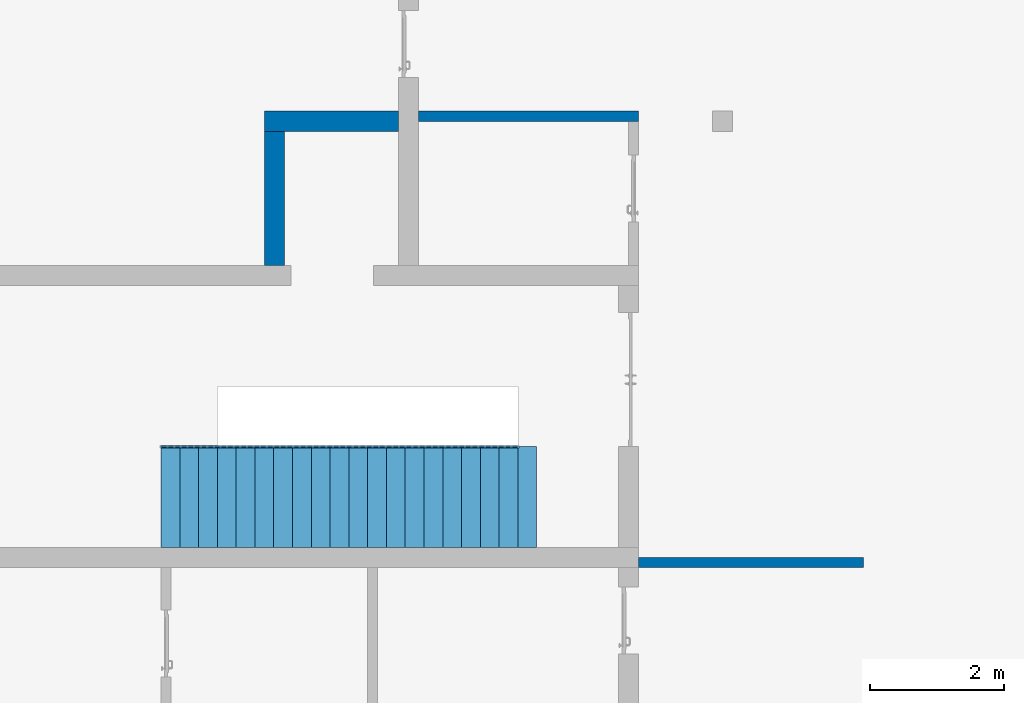
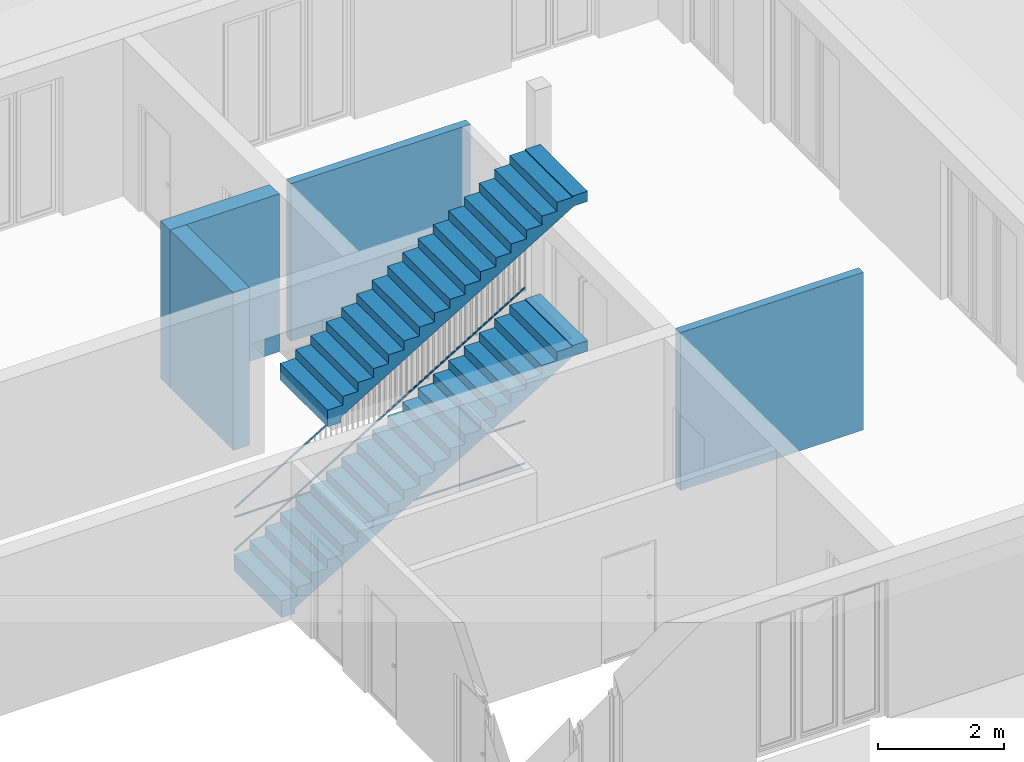
# One storey, part 19 of 23: 6 building element parts, 4 walls, 4 elements without a shape of their own.
"""IFC4 building model written with IfcOpenShell, lengths in metres."""

from ifc_helpers import new_model, entity, si_unit, converted_unit, derived_unit, direction, frame, origin_with_axes, place, context, subcontext, project, spatial, polygons, material, type_object, element, aggregate, save


model = new_model("IFC4")

# Units and contexts
model_context = context("Model", 3, precision=1e-05, world=origin_with_axes(), true_north=direction((0.0, 1.0)))
body_context = subcontext(model_context, "Body", "Model", "MODEL_VIEW")
ifc_project = project(units=[si_unit("LENGTHUNIT", "METRE"), si_unit("AREAUNIT", "SQUARE_METRE"), si_unit("VOLUMEUNIT", "CUBIC_METRE"), converted_unit("PLANEANGLEUNIT", "DEGREE", entity("IfcPlaneAngleMeasure", 0.0174532925199), si_unit("PLANEANGLEUNIT", "RADIAN"), dimensions=[0, 0, 0, 0, 0, 0, 0]), converted_unit("TIMEUNIT", "Year", entity("IfcTimeMeasure", 31556926.0), si_unit("TIMEUNIT", "SECOND"), dimensions=[0, 0, 1, 0, 0, 0, 0]), si_unit("MASSUNIT", "GRAM", prefix="KILO"), si_unit("THERMODYNAMICTEMPERATUREUNIT", "DEGREE_CELSIUS"), si_unit("LUMINOUSINTENSITYUNIT", "LUMEN"), si_unit("ENERGYUNIT", "JOULE", prefix="MEGA"), derived_unit("THERMALCONDUCTANCEUNIT", [(si_unit("POWERUNIT", "WATT"), 1), (si_unit("LENGTHUNIT", "METRE"), -1), (si_unit("THERMODYNAMICTEMPERATUREUNIT", "KELVIN"), -1)]), derived_unit("SPECIFICHEATCAPACITYUNIT", [(si_unit("ENERGYUNIT", "JOULE"), 1), (si_unit("MASSUNIT", "GRAM", prefix="KILO"), -1), (si_unit("THERMODYNAMICTEMPERATUREUNIT", "KELVIN"), -1)]), derived_unit("MASSDENSITYUNIT", [(si_unit("MASSUNIT", "GRAM", prefix="KILO"), 1), (si_unit("VOLUMEUNIT", "CUBIC_METRE"), -1)])], contexts=[model_context])

# Site, building, storey
site_placement = place(None, origin_with_axes())
site = spatial("IfcSite", under=ifc_project, at=site_placement, CompositionType="ELEMENT")
building_placement = place(site_placement, origin_with_axes())
building = spatial("IfcBuilding", under=site, at=building_placement, CompositionType="ELEMENT")
storey_placement = place(building_placement, origin_with_axes())
storey = spatial("IfcBuildingStorey", under=building, at=storey_placement, Name="0. Geschoss", CompositionType="ELEMENT", Elevation=0.0)

# Walls
ifc_material_1 = material()
wall_type_1 = type_object("IfcWallType", Name="300", PredefinedType="NOTDEFINED")
wall_1_placement = place(storey_placement, frame((-2.7421993804, 3.67118776896, 0.0), z_axis=(0.0, 0.0, 1.0), x_axis=(1.0, 0.0, 0.0)))
element("IfcWall", 1, at=wall_1_placement, inside=storey, type_object=wall_type_1, material=ifc_material_1, Name="Wand-001", PredefinedType="NOTDEFINED", context=body_context, shape_type="Tessellation", body=[
    polygons([(0.0, 0.3, 0.0), (0.0, 0.3, 3.05), (2.0, 0.3, 3.05), (2.0, 0.3, 0.0), (0.0, 0.0, 0.0), (0.0, 0.0, 3.05), (2.0, 0.0, 3.05), (2.0, 0.0, 0.0)], [[[1, 2, 3, 4]], [[5, 6, 2, 1]], [[6, 7, 3, 2]], [[4, 3, 7, 8]], [[1, 4, 8, 5]], [[8, 7, 6, 5]]], closed=True),
])
wall_2_placement = place(storey_placement, frame((-2.7421993804, 1.37118776896, 0.0), z_axis=(0.0, 0.0, 1.0), x_axis=(0.0, 1.0, 0.0)))
element("IfcWall", 2, at=wall_2_placement, inside=storey, type_object=wall_type_1, material=ifc_material_1, Name="Wand-001", PredefinedType="NOTDEFINED", context=body_context, shape_type="Tessellation", body=[
    polygons([(2.3, 0.0, 0.0), (2.3, 0.0, 3.05), (2.3, -0.3, 3.05), (2.3, -0.3, 0.0), (0.3, 0.0, 0.0), (0.3, 0.0, 3.05), (0.3, -0.3, 3.05), (0.3, -0.3, 0.0)], [[[1, 2, 3, 4]], [[5, 6, 2, 1]], [[6, 7, 3, 2]], [[4, 3, 7, 8]], [[5, 1, 4, 8]], [[8, 7, 6, 5]]], closed=True),
])
wall_type_2 = type_object("IfcWallType", Name="150", PredefinedType="NOTDEFINED")
wall_3_placement = place(storey_placement, frame((-0.742199380397, 3.97118776896, 0.0), z_axis=(0.0, 0.0, 1.0), x_axis=(1.0, 0.0, 0.0)))
element("IfcWall", 3, at=wall_3_placement, inside=storey, type_object=wall_type_2, material=ifc_material_1, Name="Wand-002", PredefinedType="NOTDEFINED", context=body_context, shape_type="Tessellation", body=[
    polygons([(0.3, 0.0, 0.0), (0.3, 0.0, 3.05), (3.58, 0.0, 3.05), (3.58, 0.0, 0.0), (0.3, -0.15, 0.0), (0.3, -0.15, 3.05), (3.58, -0.15, 3.05), (3.58, -0.15, 0.0)], [[[1, 2, 3, 4]], [[5, 6, 2, 1]], [[6, 7, 3, 2]], [[4, 3, 7, 8]], [[1, 4, 8, 5]], [[8, 7, 6, 5]]], closed=True),
])
wall_4_placement = place(storey_placement, frame((2.6878006196, -2.82881223104, 0.0), z_axis=(0.0, 0.0, 1.0), x_axis=(1.0, 0.0, 0.0)))
element("IfcWall", 4, at=wall_4_placement, inside=storey, type_object=wall_type_2, material=ifc_material_1, Name="Wand-002", PredefinedType="NOTDEFINED", context=body_context, shape_type="Tessellation", body=[
    polygons([(0.15, 0.15, 0.0), (0.15, 0.15, 3.05), (3.5, 0.15, 3.05), (3.5, 0.15, 0.0), (0.15, 0.0, 0.0), (0.15, 0.0, 3.05), (3.5, 0.0, 3.05), (3.5, 0.0, 0.0)], [[[1, 2, 3, 4]], [[5, 6, 2, 1]], [[6, 7, 3, 2]], [[4, 3, 7, 8]], [[5, 1, 4, 8]], [[8, 7, 6, 5]]], closed=True),
])

# Space
space_1_placement = place(storey_placement, frame((-11.4421993804, 1.37118776896, 0.0), z_axis=(0.0, 0.0, 1.0), x_axis=(0.0, -1.0, 0.0)))
space_1 = spatial("IfcSpace", under=storey, at=space_1_placement, CompositionType="ELEMENT", PredefinedType="INTERNAL")

# Railing, building element parts
railing_type = type_object("IfcRailingType", PredefinedType="NOTDEFINED")
railing_1_placement = place(space_1_placement, frame((1.5, 8.0, 0.0), z_axis=(0.0, 0.0, 1.0), x_axis=(0.0, 1.0, 0.0)))
railing_1 = element("IfcRailing", 5, at=railing_1_placement, inside=space_1, type_object=railing_type, PredefinedType="NOTDEFINED")
ifc_material_2 = material()
building_element_part_1_placement = place(railing_1_placement, origin_with_axes())
building_element_part_1 = element("IfcBuildingElementPart", 6, at=building_element_part_1_placement, material=ifc_material_2, PredefinedType="NOTDEFINED", context=body_context, shape_type="Tessellation", body=[
    polygons([(-0.84, -0.9125, 0.9), (-0.84, -0.9125, 0.875), (4.48, -0.9125, 0.875), (4.48, -0.9125, 0.9), (-0.84, -0.8875, 0.9), (-0.84, -0.8875, 0.875), (4.48, -0.8875, 0.875), (4.48, -0.8875, 0.9)], [[[1, 2, 3, 4]], [[1, 5, 6, 2]], [[2, 6, 7, 3]], [[4, 3, 7, 8]], [[5, 1, 4, 8]], [[6, 5, 8, 7]]], closed=True),
])
building_element_part_2_placement = place(railing_1_placement, origin_with_axes())
building_element_part_2 = element("IfcBuildingElementPart", 7, at=building_element_part_2_placement, material=ifc_material_2, PredefinedType="NOTDEFINED", context=body_context, shape_type="Tessellation", body=[
    polygons([(-0.84, -0.9125, 0.0825), (-0.84, -0.9125, 0.0575), (4.48, -0.9125, 0.0575), (4.48, -0.9125, 0.0825), (-0.84, -0.8875, 0.0825), (-0.84, -0.8875, 0.0575), (4.48, -0.8875, 0.0575), (4.48, -0.8875, 0.0825)], [[[1, 2, 3, 4]], [[1, 5, 6, 2]], [[2, 6, 7, 3]], [[4, 3, 7, 8]], [[5, 1, 4, 8]], [[6, 5, 8, 7]]], closed=True),
])
aggregate(railing_1, [building_element_part_1, building_element_part_2])

# Stair, building element part
stair_type = type_object("IfcStairType", PredefinedType="NOTDEFINED")
stair_1_placement = place(space_1_placement, frame((2.4, 7.16, 0.0), z_axis=(0.0, 0.0, 1.0), x_axis=(0.0, 1.0, 0.0)))
stair_1 = element("IfcStair", 8, at=stair_1_placement, inside=space_1, type_object=stair_type, Name="Treppe - 001", PredefinedType="NOTDEFINED")
building_element_part_3_placement = place(stair_1_placement, origin_with_axes())
building_element_part_3 = element("IfcBuildingElementPart", 9, at=building_element_part_3_placement, material=ifc_material_1, PredefinedType="NOTDEFINED", context=body_context, shape_type="Tessellation", body=[
    polygons([(5.6, 0.0, 3.25), (5.6, -1.5, 3.25), (5.6, -1.5, 3.20112016499), (5.6, 0.0, 3.20112016499), (5.32, 0.0, 3.25), (5.32, -1.5, 3.25), (5.35109619885, -1.5, 3.05), (5.6, -1.5, 3.05), (5.32, -1.5, 3.23), (5.04, -1.5, 3.23), (5.04, -1.5, 3.06), (4.76, -1.5, 3.06), (4.76, -1.5, 2.89), (4.48, -1.5, 2.89), (4.48, -1.5, 2.72), (4.2, -1.5, 2.72), (4.2, -1.5, 2.55), (3.92, -1.5, 2.55), (3.92, -1.5, 2.38), (3.64, -1.5, 2.38), (3.64, -1.5, 2.21), (3.36, -1.5, 2.21), (3.36, -1.5, 2.04), (3.08, -1.5, 2.04), (3.08, -1.5, 1.87), (2.8, -1.5, 1.87), (2.8, -1.5, 1.7), (2.52, -1.5, 1.7), (2.52, -1.5, 1.53), (2.24, -1.5, 1.53), (2.24, -1.5, 1.36), (1.96, -1.5, 1.36), (1.96, -1.5, 1.19), (1.68, -1.5, 1.19), (1.68, -1.5, 1.02), (1.4, -1.5, 1.02), (1.4, -1.5, 0.85), (1.12, -1.5, 0.85), (1.12, -1.5, 0.68), (0.84, -1.5, 0.68), (0.84, -1.5, 0.51), (0.56, -1.5, 0.51), (0.56, -1.5, 0.34), (0.28, -1.5, 0.34), (0.28, -1.5, 0.17), (0.0, -1.5, 0.17), (0.0, -1.5, -0.15), (0.25, -1.5, -0.15), (0.25, -1.5, -0.0470941207291), (0.28, -1.5, -0.0288798350148), (0.373333333333, -1.5, 0.0277868316519), (0.466666666667, -1.5, 0.0844534983185), (0.56, -1.5, 0.141120164985), (0.653333333333, -1.5, 0.197786831652), (0.746666666667, -1.5, 0.254453498319), (0.84, -1.5, 0.311120164985), (0.933333333333, -1.5, 0.367786831652), (1.02666666667, -1.5, 0.424453498319), (1.12, -1.5, 0.481120164985), (1.21333333333, -1.5, 0.537786831652), (1.30666666667, -1.5, 0.594453498319), (1.4, -1.5, 0.651120164985), (1.49333333333, -1.5, 0.707786831652), (1.58666666667, -1.5, 0.764453498319), (1.68, -1.5, 0.821120164985), (1.77333333333, -1.5, 0.877786831652), (1.86666666667, -1.5, 0.934453498319), (1.96, -1.5, 0.991120164985), (2.05333333333, -1.5, 1.04778683165), (2.14666666667, -1.5, 1.10445349832), (2.24, -1.5, 1.16112016499), (2.33333333333, -1.5, 1.21778683165), (2.42666666667, -1.5, 1.27445349832), (2.52, -1.5, 1.33112016499), (2.61333333333, -1.5, 1.38778683165), (2.70666666667, -1.5, 1.44445349832), (2.8, -1.5, 1.50112016499), (2.89333333333, -1.5, 1.55778683165), (2.98666666667, -1.5, 1.61445349832), (3.08, -1.5, 1.67112016499), (3.17333333333, -1.5, 1.72778683165), (3.26666666667, -1.5, 1.78445349832), (3.36, -1.5, 1.84112016499), (3.45333333333, -1.5, 1.89778683165), (3.54666666667, -1.5, 1.95445349832), (3.64, -1.5, 2.01112016499), (3.73333333333, -1.5, 2.06778683165), (3.82666666667, -1.5, 2.12445349832), (3.92, -1.5, 2.18112016499), (4.01333333333, -1.5, 2.23778683165), (4.10666666667, -1.5, 2.29445349832), (4.2, -1.5, 2.35112016499), (4.29333333333, -1.5, 2.40778683165), (4.38666666667, -1.5, 2.46445349832), (4.48, -1.5, 2.52112016499), (4.57333333333, -1.5, 2.57778683165), (4.66666666667, -1.5, 2.63445349832), (4.76, -1.5, 2.69112016499), (4.85333333333, -1.5, 2.74778683165), (4.94666666667, -1.5, 2.80445349832), (5.04, -1.5, 2.86112016499), (5.13333333333, -1.5, 2.91778683165), (5.22666666667, -1.5, 2.97445349832), (5.32, -1.5, 3.03112016499), (5.6, 0.0, 3.05), (5.35109619885, 0.0, 3.05), (5.32, 0.0, 3.03112016499), (5.22666666667, 0.0, 2.97445349832), (5.13333333333, 0.0, 2.91778683165), (5.04, 0.0, 2.86112016499), (4.94666666667, 0.0, 2.80445349832), (4.85333333333, 0.0, 2.74778683165), (4.76, 0.0, 2.69112016499), (4.66666666667, 0.0, 2.63445349832), (4.57333333333, 0.0, 2.57778683165), (4.48, 0.0, 2.52112016499), (4.38666666667, 0.0, 2.46445349832), (4.29333333333, 0.0, 2.40778683165), (4.2, 0.0, 2.35112016499), (4.10666666667, 0.0, 2.29445349832), (4.01333333333, 0.0, 2.23778683165), (3.92, 0.0, 2.18112016499), (3.82666666667, 0.0, 2.12445349832), (3.73333333333, 0.0, 2.06778683165), (3.64, 0.0, 2.01112016499), (3.54666666667, 0.0, 1.95445349832), (3.45333333333, 0.0, 1.89778683165), (3.36, 0.0, 1.84112016499), (3.26666666667, 0.0, 1.78445349832), (3.17333333333, 0.0, 1.72778683165), (3.08, 0.0, 1.67112016499), (2.98666666667, 0.0, 1.61445349832), (2.89333333333, 0.0, 1.55778683165), (2.8, 0.0, 1.50112016499), (2.70666666667, 0.0, 1.44445349832), (2.61333333333, 0.0, 1.38778683165), (2.52, 0.0, 1.33112016499), (2.42666666667, 0.0, 1.27445349832), (2.33333333333, 0.0, 1.21778683165), (2.24, 0.0, 1.16112016499), (2.14666666667, 0.0, 1.10445349832), (2.05333333333, 0.0, 1.04778683165), (1.96, 0.0, 0.991120164985), (1.86666666667, 0.0, 0.934453498319), (1.77333333333, 0.0, 0.877786831652), (1.68, 0.0, 0.821120164985), (1.58666666667, 0.0, 0.764453498319), (1.49333333333, 0.0, 0.707786831652), (1.4, 0.0, 0.651120164985), (1.30666666667, 0.0, 0.594453498319), (1.21333333333, 0.0, 0.537786831652), (1.12, 0.0, 0.481120164985), (1.02666666667, 0.0, 0.424453498319), (0.933333333333, 0.0, 0.367786831652), (0.84, 0.0, 0.311120164985), (0.746666666667, 0.0, 0.254453498319), (0.653333333333, 0.0, 0.197786831652), (0.56, 0.0, 0.141120164985), (0.466666666667, 0.0, 0.0844534983185), (0.373333333333, 0.0, 0.0277868316519), (0.28, 0.0, -0.0288798350148), (0.25, 0.0, -0.0470941207291), (0.25, 0.0, -0.15), (0.0, 0.0, -0.15), (0.0, 0.0, 0.17), (0.28, 0.0, 0.17), (0.28, 0.0, 0.34), (0.56, 0.0, 0.34), (0.56, 0.0, 0.51), (0.84, 0.0, 0.51), (0.84, 0.0, 0.68), (1.12, 0.0, 0.68), (1.12, 0.0, 0.85), (1.4, 0.0, 0.85), (1.4, 0.0, 1.02), (1.68, 0.0, 1.02), (1.68, 0.0, 1.19), (1.96, 0.0, 1.19), (1.96, 0.0, 1.36), (2.24, 0.0, 1.36), (2.24, 0.0, 1.53), (2.52, 0.0, 1.53), (2.52, 0.0, 1.7), (2.8, 0.0, 1.7), (2.8, 0.0, 1.87), (3.08, 0.0, 1.87), (3.08, 0.0, 2.04), (3.36, 0.0, 2.04), (3.36, 0.0, 2.21), (3.64, 0.0, 2.21), (3.64, 0.0, 2.38), (3.92, 0.0, 2.38), (3.92, 0.0, 2.55), (4.2, 0.0, 2.55), (4.2, 0.0, 2.72), (4.48, 0.0, 2.72), (4.48, 0.0, 2.89), (4.76, 0.0, 2.89), (4.76, 0.0, 3.06), (5.04, 0.0, 3.06), (5.04, 0.0, 3.23), (5.32, 0.0, 3.23)], [[[1, 2, 3, 4]], [[2, 1, 5, 6]], [[7, 8, 3, 2, 6, 9, 10, 11, 12, 13, 14, 15, 16, 17, 18, 19, 20, 21, 22, 23, 24, 25, 26, 27, 28, 29, 30, 31, 32, 33, 34, 35, 36, 37, 38, 39, 40, 41, 42, 43, 44, 45, 46, 47, 48, 49, 50, 51, 52, 53, 54, 55, 56, 57, 58, 59, 60, 61, 62, 63, 64, 65, 66, 67, 68, 69, 70, 71, 72, 73, 74, 75, 76, 77, 78, 79, 80, 81, 82, 83, 84, 85, 86, 87, 88, 89, 90, 91, 92, 93, 94, 95, 96, 97, 98, 99, 100, 101, 102, 103, 104]], [[8, 105, 4, 3]], [[5, 1, 4, 105, 106, 107, 108, 109, 110, 111, 112, 113, 114, 115, 116, 117, 118, 119, 120, 121, 122, 123, 124, 125, 126, 127, 128, 129, 130, 131, 132, 133, 134, 135, 136, 137, 138, 139, 140, 141, 142, 143, 144, 145, 146, 147, 148, 149, 150, 151, 152, 153, 154, 155, 156, 157, 158, 159, 160, 161, 162, 163, 164, 165, 166, 167, 168, 169, 170, 171, 172, 173, 174, 175, 176, 177, 178, 179, 180, 181, 182, 183, 184, 185, 186, 187, 188, 189, 190, 191, 192, 193, 194, 195, 196, 197, 198, 199, 200, 201, 202]], [[5, 202, 9, 6]], [[105, 8, 7, 106]], [[10, 9, 202, 201]], [[201, 200, 11, 10]], [[12, 11, 200, 199]], [[199, 198, 13, 12]], [[14, 13, 198, 197]], [[197, 196, 15, 14]], [[16, 15, 196, 195]], [[195, 194, 17, 16]], [[18, 17, 194, 193]], [[193, 192, 19, 18]], [[20, 19, 192, 191]], [[191, 190, 21, 20]], [[22, 21, 190, 189]], [[189, 188, 23, 22]], [[24, 23, 188, 187]], [[187, 186, 25, 24]], [[26, 25, 186, 185]], [[185, 184, 27, 26]], [[28, 27, 184, 183]], [[183, 182, 29, 28]], [[30, 29, 182, 181]], [[181, 180, 31, 30]], [[32, 31, 180, 179]], [[179, 178, 33, 32]], [[34, 33, 178, 177]], [[177, 176, 35, 34]], [[36, 35, 176, 175]], [[175, 174, 37, 36]], [[38, 37, 174, 173]], [[173, 172, 39, 38]], [[40, 39, 172, 171]], [[171, 170, 41, 40]], [[42, 41, 170, 169]], [[169, 168, 43, 42]], [[44, 43, 168, 167]], [[167, 166, 45, 44]], [[46, 45, 166, 165]], [[164, 47, 46, 165]], [[47, 164, 163, 48]], [[49, 48, 163, 162]], [[162, 161, 50, 49]], [[161, 160, 51, 50]], [[160, 159, 52, 51]], [[159, 158, 53, 52]], [[158, 157, 54, 53]], [[157, 156, 55, 54]], [[156, 155, 56, 55]], [[155, 154, 57, 56]], [[154, 153, 58, 57]], [[153, 152, 59, 58]], [[152, 151, 60, 59]], [[151, 150, 61, 60]], [[150, 149, 62, 61]], [[149, 148, 63, 62]], [[148, 147, 64, 63]], [[147, 146, 65, 64]], [[146, 145, 66, 65]], [[145, 144, 67, 66]], [[144, 143, 68, 67]], [[143, 142, 69, 68]], [[142, 141, 70, 69]], [[141, 140, 71, 70]], [[140, 139, 72, 71]], [[139, 138, 73, 72]], [[138, 137, 74, 73]], [[137, 136, 75, 74]], [[136, 135, 76, 75]], [[135, 134, 77, 76]], [[134, 133, 78, 77]], [[133, 132, 79, 78]], [[132, 131, 80, 79]], [[131, 130, 81, 80]], [[130, 129, 82, 81]], [[129, 128, 83, 82]], [[128, 127, 84, 83]], [[127, 126, 85, 84]], [[126, 125, 86, 85]], [[125, 124, 87, 86]], [[124, 123, 88, 87]], [[123, 122, 89, 88]], [[122, 121, 90, 89]], [[121, 120, 91, 90]], [[120, 119, 92, 91]], [[119, 118, 93, 92]], [[118, 117, 94, 93]], [[117, 116, 95, 94]], [[116, 115, 96, 95]], [[115, 114, 97, 96]], [[114, 113, 98, 97]], [[113, 112, 99, 98]], [[112, 111, 100, 99]], [[111, 110, 101, 100]], [[110, 109, 102, 101]], [[109, 108, 103, 102]], [[108, 107, 104, 103]], [[104, 107, 106, 7]]], closed=True),
])
aggregate(stair_1, [building_element_part_3])

# Railing, building element parts
railing_2_placement = place(space_1_placement, frame((2.4, 7.16, 0.17), z_axis=(0.0, 0.0, 1.0), x_axis=(0.0, 1.0, 0.0)))
railing_2 = element("IfcRailing", 10, at=railing_2_placement, inside=space_1, type_object=railing_type, PredefinedType="NOTDEFINED")
building_element_part_4_placement = place(railing_2_placement, origin_with_axes())
building_element_part_4 = element("IfcBuildingElementPart", 11, at=building_element_part_4_placement, material=ifc_material_2, PredefinedType="NOTDEFINED", context=body_context, shape_type="Tessellation", body=[
    polygons([(0.0, -0.0125, 0.9), (0.012974453356, -0.0125, 0.878630312119), (5.33297445336, -0.0125, 4.10863031212), (5.32, -0.0125, 4.13), (0.0, 0.0125, 0.9), (0.012974453356, 0.0125, 0.878630312119), (5.33297445336, 0.0125, 4.10863031212), (5.32, 0.0125, 4.13)], [[[1, 2, 3, 4]], [[1, 5, 6, 2]], [[2, 6, 7, 3]], [[4, 3, 7, 8]], [[5, 1, 4, 8]], [[6, 5, 8, 7]]], closed=True),
])
building_element_part_5_placement = place(railing_2_placement, origin_with_axes())
building_element_part_5 = element("IfcBuildingElementPart", 12, at=building_element_part_5_placement, material=ifc_material_2, PredefinedType="NOTDEFINED", context=body_context, shape_type="Tessellation", body=[
    polygons([(-0.00648722667802, -0.0125, 0.0806848439403), (0.00648722667802, -0.0125, 0.0593151560597), (5.32648722668, -0.0125, 3.28931515606), (5.31351277332, -0.0125, 3.31068484394), (-0.00648722667802, 0.0125, 0.0806848439403), (0.00648722667802, 0.0125, 0.0593151560597), (5.32648722668, 0.0125, 3.28931515606), (5.31351277332, 0.0125, 3.31068484394)], [[[1, 2, 3, 4]], [[1, 5, 6, 2]], [[2, 6, 7, 3]], [[4, 3, 7, 8]], [[5, 1, 4, 8]], [[6, 5, 8, 7]]], closed=True),
])
aggregate(railing_2, [building_element_part_4, building_element_part_5])

# Space
space_2_placement = place(storey_placement, frame((-3.4421993804, -2.52881223104, 0.0), z_axis=(0.0, 0.0, 1.0), x_axis=(1.0, 0.0, 0.0)))
space_2 = spatial("IfcSpace", under=storey, at=space_2_placement, CompositionType="ELEMENT", PredefinedType="INTERNAL")

# Stair, building element part
stair_2_placement = place(space_2_placement, frame((0.0, 1.5, 3.4), z_axis=(0.0, 0.0, 1.0), x_axis=(1.0, 0.0, 0.0)))
stair_2 = element("IfcStair", 13, at=stair_2_placement, inside=space_2, type_object=stair_type, Name="Treppe - 001", PredefinedType="NOTDEFINED")
building_element_part_6_placement = place(stair_2_placement, origin_with_axes())
building_element_part_6 = element("IfcBuildingElementPart", 14, at=building_element_part_6_placement, material=ifc_material_1, PredefinedType="NOTDEFINED", context=body_context, shape_type="Tessellation", body=[
    polygons([(4.76, 0.0, 2.74), (4.76, -1.5, 2.74), (4.76, -1.5, 2.69112016499), (4.76, 0.0, 2.69112016499), (4.48, 0.0, 2.74), (4.48, -1.5, 2.74), (4.51109619885, -1.5, 2.54), (4.76, -1.5, 2.54), (4.48, -1.5, 2.72), (4.2, -1.5, 2.72), (4.2, -1.5, 2.55), (3.92, -1.5, 2.55), (3.92, -1.5, 2.38), (3.64, -1.5, 2.38), (3.64, -1.5, 2.21), (3.36, -1.5, 2.21), (3.36, -1.5, 2.04), (3.08, -1.5, 2.04), (3.08, -1.5, 1.87), (2.8, -1.5, 1.87), (2.8, -1.5, 1.7), (2.52, -1.5, 1.7), (2.52, -1.5, 1.53), (2.24, -1.5, 1.53), (2.24, -1.5, 1.36), (1.96, -1.5, 1.36), (1.96, -1.5, 1.19), (1.68, -1.5, 1.19), (1.68, -1.5, 1.02), (1.4, -1.5, 1.02), (1.4, -1.5, 0.85), (1.12, -1.5, 0.85), (1.12, -1.5, 0.68), (0.84, -1.5, 0.68), (0.84, -1.5, 0.51), (0.56, -1.5, 0.51), (0.56, -1.5, 0.34), (0.28, -1.5, 0.34), (0.28, -1.5, 0.17), (0.0, -1.5, 0.17), (0.0, -1.5, -0.15), (0.25, -1.5, -0.15), (0.25, -1.5, -0.0470941207291), (0.28, -1.5, -0.0288798350148), (0.373333333333, -1.5, 0.0277868316519), (0.466666666667, -1.5, 0.0844534983185), (0.56, -1.5, 0.141120164985), (0.653333333333, -1.5, 0.197786831652), (0.746666666667, -1.5, 0.254453498319), (0.84, -1.5, 0.311120164985), (0.933333333333, -1.5, 0.367786831652), (1.02666666667, -1.5, 0.424453498319), (1.12, -1.5, 0.481120164985), (1.21333333333, -1.5, 0.537786831652), (1.30666666667, -1.5, 0.594453498319), (1.4, -1.5, 0.651120164985), (1.49333333333, -1.5, 0.707786831652), (1.58666666667, -1.5, 0.764453498319), (1.68, -1.5, 0.821120164985), (1.77333333333, -1.5, 0.877786831652), (1.86666666667, -1.5, 0.934453498319), (1.96, -1.5, 0.991120164985), (2.05333333333, -1.5, 1.04778683165), (2.14666666667, -1.5, 1.10445349832), (2.24, -1.5, 1.16112016499), (2.33333333333, -1.5, 1.21778683165), (2.42666666667, -1.5, 1.27445349832), (2.52, -1.5, 1.33112016499), (2.61333333333, -1.5, 1.38778683165), (2.70666666667, -1.5, 1.44445349832), (2.8, -1.5, 1.50112016499), (2.89333333333, -1.5, 1.55778683165), (2.98666666667, -1.5, 1.61445349832), (3.08, -1.5, 1.67112016499), (3.17333333333, -1.5, 1.72778683165), (3.26666666667, -1.5, 1.78445349832), (3.36, -1.5, 1.84112016499), (3.45333333333, -1.5, 1.89778683165), (3.54666666667, -1.5, 1.95445349832), (3.64, -1.5, 2.01112016499), (3.73333333333, -1.5, 2.06778683165), (3.82666666667, -1.5, 2.12445349832), (3.92, -1.5, 2.18112016499), (4.01333333333, -1.5, 2.23778683165), (4.10666666667, -1.5, 2.29445349832), (4.2, -1.5, 2.35112016499), (4.29333333333, -1.5, 2.40778683165), (4.38666666667, -1.5, 2.46445349832), (4.48, -1.5, 2.52112016499), (4.76, 0.0, 2.54), (4.51109619885, 0.0, 2.54), (4.48, 0.0, 2.52112016499), (4.38666666667, 0.0, 2.46445349832), (4.29333333333, 0.0, 2.40778683165), (4.2, 0.0, 2.35112016499), (4.10666666667, 0.0, 2.29445349832), (4.01333333333, 0.0, 2.23778683165), (3.92, 0.0, 2.18112016499), (3.82666666667, 0.0, 2.12445349832), (3.73333333333, 0.0, 2.06778683165), (3.64, 0.0, 2.01112016499), (3.54666666667, 0.0, 1.95445349832), (3.45333333333, 0.0, 1.89778683165), (3.36, 0.0, 1.84112016499), (3.26666666667, 0.0, 1.78445349832), (3.17333333333, 0.0, 1.72778683165), (3.08, 0.0, 1.67112016499), (2.98666666667, 0.0, 1.61445349832), (2.89333333333, 0.0, 1.55778683165), (2.8, 0.0, 1.50112016499), (2.70666666667, 0.0, 1.44445349832), (2.61333333333, 0.0, 1.38778683165), (2.52, 0.0, 1.33112016499), (2.42666666667, 0.0, 1.27445349832), (2.33333333333, 0.0, 1.21778683165), (2.24, 0.0, 1.16112016499), (2.14666666667, 0.0, 1.10445349832), (2.05333333333, 0.0, 1.04778683165), (1.96, 0.0, 0.991120164985), (1.86666666667, 0.0, 0.934453498319), (1.77333333333, 0.0, 0.877786831652), (1.68, 0.0, 0.821120164985), (1.58666666667, 0.0, 0.764453498319), (1.49333333333, 0.0, 0.707786831652), (1.4, 0.0, 0.651120164985), (1.30666666667, 0.0, 0.594453498319), (1.21333333333, 0.0, 0.537786831652), (1.12, 0.0, 0.481120164985), (1.02666666667, 0.0, 0.424453498319), (0.933333333333, 0.0, 0.367786831652), (0.84, 0.0, 0.311120164985), (0.746666666667, 0.0, 0.254453498319), (0.653333333333, 0.0, 0.197786831652), (0.56, 0.0, 0.141120164985), (0.466666666667, 0.0, 0.0844534983185), (0.373333333333, 0.0, 0.0277868316519), (0.28, 0.0, -0.0288798350148), (0.25, 0.0, -0.0470941207291), (0.25, 0.0, -0.15), (0.0, 0.0, -0.15), (0.0, 0.0, 0.17), (0.28, 0.0, 0.17), (0.28, 0.0, 0.34), (0.56, 0.0, 0.34), (0.56, 0.0, 0.51), (0.84, 0.0, 0.51), (0.84, 0.0, 0.68), (1.12, 0.0, 0.68), (1.12, 0.0, 0.85), (1.4, 0.0, 0.85), (1.4, 0.0, 1.02), (1.68, 0.0, 1.02), (1.68, 0.0, 1.19), (1.96, 0.0, 1.19), (1.96, 0.0, 1.36), (2.24, 0.0, 1.36), (2.24, 0.0, 1.53), (2.52, 0.0, 1.53), (2.52, 0.0, 1.7), (2.8, 0.0, 1.7), (2.8, 0.0, 1.87), (3.08, 0.0, 1.87), (3.08, 0.0, 2.04), (3.36, 0.0, 2.04), (3.36, 0.0, 2.21), (3.64, 0.0, 2.21), (3.64, 0.0, 2.38), (3.92, 0.0, 2.38), (3.92, 0.0, 2.55), (4.2, 0.0, 2.55), (4.2, 0.0, 2.72), (4.48, 0.0, 2.72)], [[[1, 2, 3, 4]], [[2, 1, 5, 6]], [[7, 8, 3, 2, 6, 9, 10, 11, 12, 13, 14, 15, 16, 17, 18, 19, 20, 21, 22, 23, 24, 25, 26, 27, 28, 29, 30, 31, 32, 33, 34, 35, 36, 37, 38, 39, 40, 41, 42, 43, 44, 45, 46, 47, 48, 49, 50, 51, 52, 53, 54, 55, 56, 57, 58, 59, 60, 61, 62, 63, 64, 65, 66, 67, 68, 69, 70, 71, 72, 73, 74, 75, 76, 77, 78, 79, 80, 81, 82, 83, 84, 85, 86, 87, 88, 89]], [[8, 90, 4, 3]], [[5, 1, 4, 90, 91, 92, 93, 94, 95, 96, 97, 98, 99, 100, 101, 102, 103, 104, 105, 106, 107, 108, 109, 110, 111, 112, 113, 114, 115, 116, 117, 118, 119, 120, 121, 122, 123, 124, 125, 126, 127, 128, 129, 130, 131, 132, 133, 134, 135, 136, 137, 138, 139, 140, 141, 142, 143, 144, 145, 146, 147, 148, 149, 150, 151, 152, 153, 154, 155, 156, 157, 158, 159, 160, 161, 162, 163, 164, 165, 166, 167, 168, 169, 170, 171, 172]], [[5, 172, 9, 6]], [[90, 8, 7, 91]], [[10, 9, 172, 171]], [[171, 170, 11, 10]], [[12, 11, 170, 169]], [[169, 168, 13, 12]], [[14, 13, 168, 167]], [[167, 166, 15, 14]], [[16, 15, 166, 165]], [[165, 164, 17, 16]], [[18, 17, 164, 163]], [[163, 162, 19, 18]], [[20, 19, 162, 161]], [[161, 160, 21, 20]], [[22, 21, 160, 159]], [[159, 158, 23, 22]], [[24, 23, 158, 157]], [[157, 156, 25, 24]], [[26, 25, 156, 155]], [[155, 154, 27, 26]], [[28, 27, 154, 153]], [[153, 152, 29, 28]], [[30, 29, 152, 151]], [[151, 150, 31, 30]], [[32, 31, 150, 149]], [[149, 148, 33, 32]], [[34, 33, 148, 147]], [[147, 146, 35, 34]], [[36, 35, 146, 145]], [[145, 144, 37, 36]], [[38, 37, 144, 143]], [[143, 142, 39, 38]], [[40, 39, 142, 141]], [[140, 41, 40, 141]], [[41, 140, 139, 42]], [[43, 42, 139, 138]], [[138, 137, 44, 43]], [[137, 136, 45, 44]], [[136, 135, 46, 45]], [[135, 134, 47, 46]], [[134, 133, 48, 47]], [[133, 132, 49, 48]], [[132, 131, 50, 49]], [[131, 130, 51, 50]], [[130, 129, 52, 51]], [[129, 128, 53, 52]], [[128, 127, 54, 53]], [[127, 126, 55, 54]], [[126, 125, 56, 55]], [[125, 124, 57, 56]], [[124, 123, 58, 57]], [[123, 122, 59, 58]], [[122, 121, 60, 59]], [[121, 120, 61, 60]], [[120, 119, 62, 61]], [[119, 118, 63, 62]], [[118, 117, 64, 63]], [[117, 116, 65, 64]], [[116, 115, 66, 65]], [[115, 114, 67, 66]], [[114, 113, 68, 67]], [[113, 112, 69, 68]], [[112, 111, 70, 69]], [[111, 110, 71, 70]], [[110, 109, 72, 71]], [[109, 108, 73, 72]], [[108, 107, 74, 73]], [[107, 106, 75, 74]], [[106, 105, 76, 75]], [[105, 104, 77, 76]], [[104, 103, 78, 77]], [[103, 102, 79, 78]], [[102, 101, 80, 79]], [[101, 100, 81, 80]], [[100, 99, 82, 81]], [[99, 98, 83, 82]], [[98, 97, 84, 83]], [[97, 96, 85, 84]], [[96, 95, 86, 85]], [[95, 94, 87, 86]], [[94, 93, 88, 87]], [[93, 92, 89, 88]], [[89, 92, 91, 7]]], closed=True),
])
aggregate(stair_2, [building_element_part_6])

save(model, "model.ifc")
